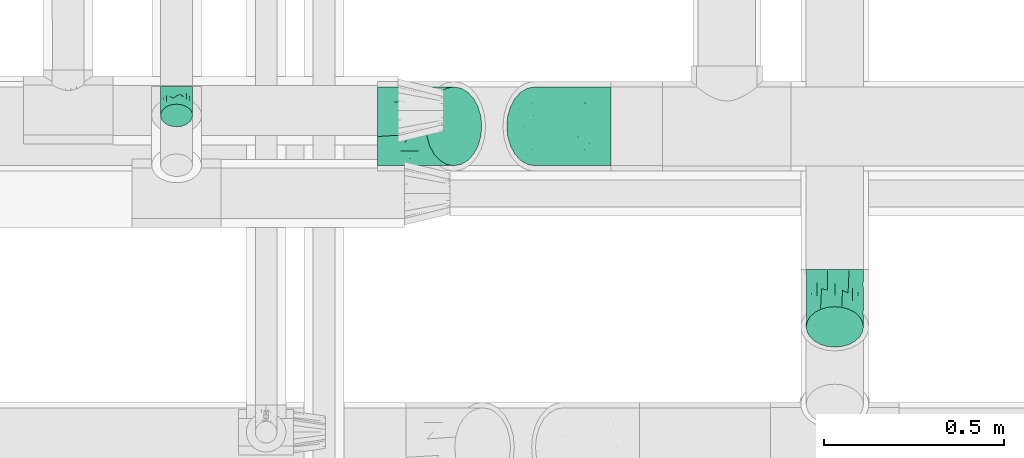
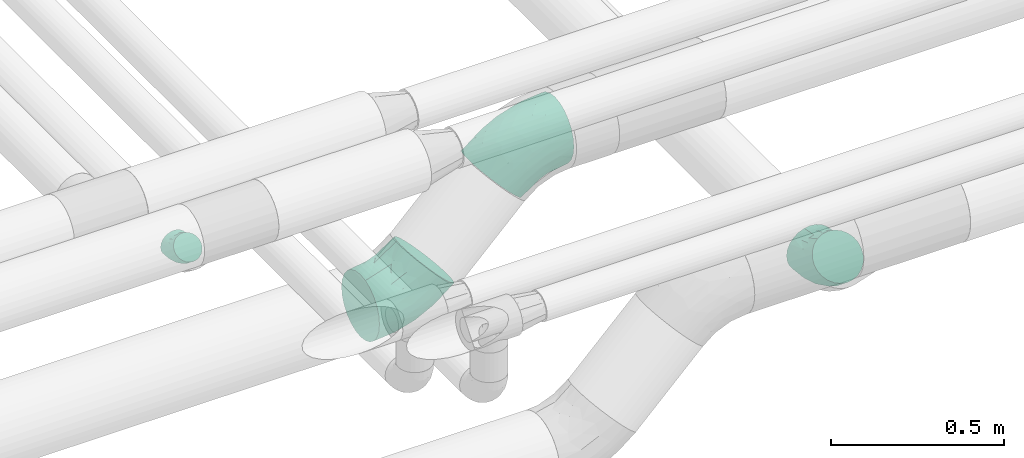
# One storey, part 795 of 827: 4 flow fittings.
"""IFC2X3 building model written with IfcOpenShell, lengths in millimetres."""

from ifc_helpers import new_model, entity, si_unit, converted_unit, derived_unit, direction, frame, origin, place, context, subcontext, project, spatial, faceted_brep, source, transform, mapped, material, type_object, type_shapes, element, save


model = new_model("IFC2X3")

# Units and contexts
model_context = context("Model", 3, precision=0.01, world=origin(), true_north=direction((6.12303176911189e-17, 1.0)))
body_context = subcontext(model_context, "Body", "Model", "MODEL_VIEW")
ifc_project = project(units=[si_unit("LENGTHUNIT", "METRE", prefix="MILLI"), si_unit("AREAUNIT", "SQUARE_METRE"), si_unit("VOLUMEUNIT", "CUBIC_METRE"), converted_unit("PLANEANGLEUNIT", "DEGREE", entity("IfcRatioMeasure", 0.0174532925199433), si_unit("PLANEANGLEUNIT", "RADIAN"), dimensions=[0, 0, 0, 0, 0, 0, 0]), si_unit("MASSUNIT", "GRAM", prefix="KILO"), derived_unit("MASSDENSITYUNIT", [(si_unit("MASSUNIT", "GRAM", prefix="KILO"), 1), (si_unit("LENGTHUNIT", "METRE"), -3)]), derived_unit("MOMENTOFINERTIAUNIT", [(si_unit("LENGTHUNIT", "METRE"), 4)]), si_unit("TIMEUNIT", "SECOND"), si_unit("FREQUENCYUNIT", "HERTZ"), si_unit("THERMODYNAMICTEMPERATUREUNIT", "DEGREE_CELSIUS"), derived_unit("THERMALTRANSMITTANCEUNIT", [(si_unit("MASSUNIT", "GRAM", prefix="KILO"), 1), (si_unit("THERMODYNAMICTEMPERATUREUNIT", "KELVIN"), -1), (si_unit("TIMEUNIT", "SECOND"), -3)]), derived_unit("VOLUMETRICFLOWRATEUNIT", [(si_unit("LENGTHUNIT", "METRE"), 3), (si_unit("TIMEUNIT", "SECOND"), -1)]), derived_unit("MASSFLOWRATEUNIT", [(si_unit("MASSUNIT", "GRAM", prefix="KILO"), 1), (si_unit("TIMEUNIT", "SECOND"), -1)]), derived_unit("ROTATIONALFREQUENCYUNIT", [(si_unit("TIMEUNIT", "SECOND"), -1)]), si_unit("ELECTRICCURRENTUNIT", "AMPERE"), si_unit("ELECTRICVOLTAGEUNIT", "VOLT"), si_unit("POWERUNIT", "WATT"), si_unit("FORCEUNIT", "NEWTON", prefix="KILO"), si_unit("ILLUMINANCEUNIT", "LUX"), si_unit("LUMINOUSFLUXUNIT", "LUMEN"), si_unit("LUMINOUSINTENSITYUNIT", "CANDELA"), derived_unit("USERDEFINED", [(si_unit("MASSUNIT", "GRAM", prefix="KILO"), -1), (si_unit("LENGTHUNIT", "METRE"), -2), (si_unit("TIMEUNIT", "SECOND"), 3), (si_unit("LUMINOUSFLUXUNIT", "LUMEN"), 1)]), derived_unit("LINEARVELOCITYUNIT", [(si_unit("LENGTHUNIT", "METRE"), 1), (si_unit("TIMEUNIT", "SECOND"), -1)]), si_unit("PRESSUREUNIT", "PASCAL"), derived_unit("USERDEFINED", [(si_unit("LENGTHUNIT", "METRE"), -2), (si_unit("MASSUNIT", "GRAM", prefix="KILO"), 1), (si_unit("TIMEUNIT", "SECOND"), -2)]), derived_unit("LINEARFORCEUNIT", [(si_unit("MASSUNIT", "GRAM", prefix="KILO"), 1), (si_unit("LENGTHUNIT", "METRE"), 1), (si_unit("TIMEUNIT", "SECOND"), -2), (si_unit("LENGTHUNIT", "METRE"), -1)]), derived_unit("PLANARFORCEUNIT", [(si_unit("MASSUNIT", "GRAM", prefix="KILO"), 1), (si_unit("LENGTHUNIT", "METRE"), 1), (si_unit("TIMEUNIT", "SECOND"), -2), (si_unit("LENGTHUNIT", "METRE"), -2)])], contexts=[model_context])

# Site, building, storey
site_placement = place(None, origin())
site = spatial("IfcSite", under=ifc_project, at=site_placement, CompositionType="ELEMENT")
building_placement = place(site_placement, origin())
building = spatial("IfcBuilding", under=site, at=building_placement, CompositionType="ELEMENT")
storey_placement = place(building_placement, frame((0.0, 0.0, 28200.0)))
storey = spatial("IfcBuildingStorey", under=building, at=storey_placement, Name="08", CompositionType="ELEMENT", Elevation=28200.0)

# Flow fittings
ifc_material = material()
pipe_fitting_type_1 = type_object("IfcPipeFittingType", Name="ADSK_1", PredefinedType="NOTDEFINED", material=ifc_material)
shared_shape_1 = source(origin(), body_context, "Body", "Brep", [
    faceted_brep([(-47.22, 22.22, -38.49), (-47.22, 11.5, -42.94), (-47.22, 0.0, -44.45), (-47.22, -11.5, -42.94), (-47.22, -22.23, -38.49), (-47.22, -31.43, -31.43), (-47.22, -38.49, -22.23), (-47.22, -42.94, -11.5), (-47.22, -44.45, 0.0), (-47.22, -42.94, 11.5), (-47.22, -38.49, 22.22), (-47.22, -31.43, 31.43), (-47.22, -22.23, 38.49), (-47.22, -11.5, 42.94), (-47.22, 0.0, 44.45), (-47.22, 11.5, 42.94), (-47.22, 22.22, 38.49), (-47.22, 31.43, 31.43), (-47.22, 38.49, 22.22), (-47.22, 42.94, 11.5), (-47.22, 44.45, 0.0), (-47.22, 42.94, -11.5), (-47.22, 38.49, -22.23), (-47.22, 31.43, -31.43), (33.39, 33.39, -44.45), (25.25, 41.52, -42.94), (17.67, 49.11, -38.49), (11.16, 55.61, -31.43), (6.17, 60.61, -22.23), (3.03, 63.75, -11.5), (1.96, 64.82, 0.0), (3.03, 63.75, 11.5), (6.17, 60.61, 22.22), (11.16, 55.61, 31.43), (17.67, 49.11, 38.49), (25.25, 41.52, 42.94), (33.39, 33.39, 44.45), (41.52, 25.25, 42.94), (49.11, 17.67, 38.49), (55.61, 11.16, 31.43), (60.61, 6.17, 22.22), (63.75, 3.03, 11.5), (64.82, 1.96, 0.0), (63.75, 3.03, -11.5), (60.61, 6.17, -22.23), (55.61, 11.16, -31.43), (49.11, 17.67, -38.49), (41.52, 25.25, -42.94), (-19.98, -33.35, 26.29), (-11.97, -37.49, 15.83), (10.37, -25.04, 25.37), (-25.25, -41.56, 0.0), (-6.21, -39.05, 0.0), (-16.68, -40.78, 7.79), (-13.8, -24.01, 34.53), (37.71, -9.45, 26.29), (6.35, -15.34, 36.05), (-23.74, -15.68, 40.73), (15.3, 24.82, 44.16), (-17.26, -3.14, 43.91), (-5.19, 12.53, 44.25), (-28.37, 6.73, 44.16), (26.74, -7.21, 34.53), (27.87, 5.7, 40.73), (-21.13, 19.57, 41.46), (-13.51, 32.62, 36.11), (13.22, -28.64, 17.37), (13.09, -31.61, 8.64), (-23.75, 38.2, 27.85), (-19.13, 46.18, 18.12), (40.63, -17.04, 7.79), (47.24, -11.53, 0.0), (-14.96, 51.28, 9.26), (14.43, 9.99, 43.91), (3.57, -8.62, 40.32), (-4.38, 47.42, 27.62), (34.97, -18.05, 15.83), (3.7, 30.44, 41.41), (-20.6, 49.74, 0.0), (12.9, -31.14, 0.0), (32.0, -23.22, 0.0), (-17.26, -3.14, -43.91), (-16.68, -40.78, -7.79), (13.07, -31.55, -8.93), (1.1, 28.78, -41.46), (-28.37, 6.73, -44.16), (-19.13, 46.18, -18.12), (26.74, -7.21, -34.53), (-13.51, 32.62, -36.11), (34.97, -18.05, -15.83), (-30.43, 36.63, -27.62), (14.43, 9.99, -43.91), (-25.68, 46.84, -9.26), (-24.14, 18.91, -41.41), (-11.97, -37.49, -15.83), (37.71, -9.45, -26.29), (-19.98, -33.35, -26.29), (10.37, -25.04, -25.37), (10.46, -29.71, -17.51), (-13.8, -24.01, -34.53), (6.35, -15.34, -36.05), (3.57, -8.62, -40.32), (27.87, 5.7, -40.73), (-23.74, -15.68, -40.73), (-10.21, 43.8, -27.85), (40.63, -17.04, -7.79), (15.3, 24.82, -44.16), (-5.19, 12.53, -44.25)], [[[0, 1, 2, 3, 4, 5, 6, 7, 8, 9, 10, 11, 12, 13, 14, 15, 16, 17, 18, 19, 20, 21, 22, 23]], [[24, 25, 26, 27, 28, 29, 30, 31, 32, 33, 34, 35, 36, 37, 38, 39, 40, 41, 42, 43, 44, 45, 46, 47]], [[48, 49, 50]], [[51, 52, 53]], [[12, 11, 54]], [[40, 39, 55]], [[54, 56, 57]], [[48, 11, 10]], [[36, 35, 58]], [[13, 12, 57]], [[59, 60, 61]], [[14, 13, 59]], [[62, 55, 39]], [[38, 37, 63]], [[61, 15, 14]], [[16, 64, 65]], [[9, 51, 53]], [[34, 33, 65]], [[66, 49, 67]], [[65, 17, 16]], [[18, 17, 68]], [[18, 68, 69]], [[19, 18, 69]], [[41, 70, 71]], [[72, 20, 19]], [[52, 67, 53]], [[49, 53, 67]], [[16, 15, 64]], [[36, 58, 73]], [[39, 38, 62]], [[74, 73, 59]], [[73, 37, 36]], [[75, 65, 33]], [[76, 40, 55]], [[60, 58, 77]], [[62, 38, 63]], [[17, 65, 68]], [[70, 41, 76]], [[49, 48, 10]], [[61, 64, 15]], [[56, 50, 62]], [[19, 69, 72]], [[10, 9, 49]], [[78, 72, 30]], [[48, 54, 11]], [[31, 72, 69]], [[74, 63, 73]], [[69, 68, 75]], [[55, 62, 50]], [[32, 75, 33]], [[57, 59, 13]], [[35, 34, 77]], [[77, 65, 64]], [[56, 74, 57]], [[60, 59, 73]], [[76, 41, 40]], [[54, 48, 50]], [[32, 31, 69]], [[76, 55, 50]], [[65, 77, 34]], [[60, 77, 64]], [[54, 57, 12]], [[59, 57, 74]], [[73, 63, 37]], [[63, 74, 56]], [[9, 8, 51]], [[67, 52, 79, 80]], [[9, 53, 49]], [[70, 67, 80]], [[67, 76, 66]], [[71, 70, 80]], [[71, 42, 41]], [[67, 70, 76]], [[59, 61, 14]], [[64, 61, 60]], [[77, 58, 35]], [[73, 58, 60]], [[69, 75, 32]], [[65, 75, 68]], [[30, 72, 31]], [[72, 78, 20]], [[50, 56, 54]], [[63, 56, 62]], [[76, 50, 66]], [[49, 66, 50]], [[3, 2, 81]], [[52, 82, 83]], [[26, 25, 84]], [[2, 1, 85]], [[86, 22, 21]], [[46, 45, 87]], [[88, 0, 23]], [[44, 43, 89]], [[22, 90, 23]], [[24, 47, 91]], [[86, 21, 92]], [[1, 0, 93]], [[82, 7, 94]], [[89, 95, 44]], [[96, 97, 98]], [[96, 94, 6]], [[5, 4, 99]], [[100, 101, 102]], [[7, 6, 94]], [[5, 96, 6]], [[103, 4, 3]], [[90, 88, 23]], [[99, 96, 5]], [[28, 27, 104]], [[20, 78, 92]], [[27, 88, 104]], [[30, 29, 92]], [[100, 97, 99]], [[88, 84, 93]], [[28, 86, 29]], [[27, 26, 88]], [[103, 99, 4]], [[84, 88, 26]], [[104, 90, 86]], [[85, 81, 2]], [[104, 86, 28]], [[43, 71, 105]], [[106, 25, 24]], [[102, 47, 46]], [[7, 82, 51]], [[44, 95, 45]], [[102, 87, 100]], [[95, 87, 45]], [[107, 106, 91]], [[97, 95, 89]], [[107, 91, 81]], [[105, 71, 80]], [[102, 91, 47]], [[101, 103, 81]], [[82, 94, 83]], [[101, 81, 91]], [[98, 89, 83]], [[106, 84, 25]], [[29, 86, 92]], [[107, 85, 93]], [[96, 99, 97]], [[87, 95, 97]], [[88, 93, 0]], [[107, 93, 84]], [[81, 103, 3]], [[103, 101, 100]], [[87, 102, 46]], [[91, 102, 101]], [[51, 82, 52]], [[51, 8, 7]], [[98, 83, 94]], [[105, 83, 89]], [[83, 80, 79, 52]], [[43, 42, 71]], [[83, 105, 80]], [[43, 105, 89]], [[93, 85, 1]], [[81, 85, 107]], [[91, 106, 24]], [[84, 106, 107]], [[86, 90, 22]], [[88, 90, 104]], [[20, 92, 21]], [[92, 78, 30]], [[97, 100, 87]], [[103, 100, 99]], [[96, 98, 94]], [[89, 98, 97]]]),
])
type_shapes(pipe_fitting_type_1, [shared_shape_1])
flow_fitting_1_placement = place(storey_placement, frame((36220.03, 7329.73, 2850.0), z_axis=(-1.0, 0.0, 0.0), x_axis=(0.0, -1.0, 0.0)))
element("IfcFlowFitting", 1, at=flow_fitting_1_placement, inside=storey, type_object=pipe_fitting_type_1, material=ifc_material, Name="ADSK_1", ObjectType="ADSK_1", context=body_context, shape_type="MappedRepresentation", body=[
    mapped(shared_shape_1, transform((0.0, 0.0, 0.0), scale=1.0)),
])
pipe_fitting_type_2 = type_object("IfcPipeFittingType", Name="ADSK_2", PredefinedType="NOTDEFINED", material=ifc_material)
shared_shape_2 = source(origin(), body_context, "Body", "Brep", [
    faceted_brep([(-124.26, 54.75, -94.83), (-124.26, 28.34, -105.77), (-124.26, 0.0, -109.5), (-124.26, -28.34, -105.77), (-124.26, -54.75, -94.83), (-124.26, -77.43, -77.43), (-124.26, -94.83, -54.75), (-124.26, -105.77, -28.34), (-124.26, -109.5, 0.0), (-124.26, -105.77, 28.34), (-124.26, -94.83, 54.75), (-124.26, -77.43, 77.43), (-124.26, -54.75, 94.83), (-124.26, -28.34, 105.77), (-124.26, 0.0, 109.5), (-124.26, 28.34, 105.77), (-124.26, 54.75, 94.83), (-124.26, 77.43, 77.43), (-124.26, 94.83, 54.75), (-124.26, 105.77, 28.34), (-124.26, 109.5, 0.0), (-124.26, 105.77, -28.34), (-124.26, 94.83, -54.75), (-124.26, 77.43, -77.43), (87.87, 87.86, -109.5), (67.83, 107.9, -105.77), (49.15, 126.58, -94.83), (33.12, 142.61, -77.43), (20.81, 154.92, -54.75), (13.08, 162.65, -28.34), (10.44, 165.29, 0.0), (13.08, 162.65, 28.34), (20.81, 154.92, 54.75), (33.12, 142.61, 77.43), (49.15, 126.58, 94.83), (67.83, 107.9, 105.77), (87.87, 87.86, 109.5), (107.91, 67.82, 105.77), (126.58, 49.15, 94.83), (142.62, 33.11, 77.43), (154.92, 20.81, 54.75), (162.66, 13.07, 28.34), (165.29, 10.43, 0.0), (162.66, 13.07, -28.34), (154.92, 20.81, -54.75), (142.62, 33.11, -77.43), (126.58, 49.15, -94.83), (107.91, 67.82, -105.77), (71.65, 17.62, 100.41), (2.28, -89.46, 0.0), (-32.68, -94.9, 29.76), (-60.2, -104.46, 0.0), (40.7, 64.69, 108.77), (-50.5, -81.19, 64.81), (-37.02, -58.34, 85.18), (-45.56, -6.91, 108.2), (14.88, -35.92, 89.14), (-63.13, -38.21, 100.41), (-13.48, 32.55, 108.99), (10.95, 77.8, 101.97), (-55.1, 49.0, 102.07), (-33.95, 81.95, 88.86), (-74.53, 16.96, 108.77), (31.61, -76.31, 21.78), (90.21, -44.0, 29.76), (-61.62, 94.79, 68.49), (-47.74, 115.26, 44.52), (27.74, -66.97, 50.42), (-65.18, -94.31, 47.39), (-34.75, 129.14, 22.76), (-87.1, 113.16, 0.0), (61.64, -64.87, 0.0), (116.43, -31.3, 0.0), (67.43, -15.08, 85.18), (80.19, -41.7, 48.45), (93.12, -21.7, 64.81), (37.1, 27.33, 108.2), (15.29, -56.47, 71.64), (-8.95, 119.52, 68.0), (-18.43, 141.6, 0.0), (-51.36, 124.0, 0.0), (8.08, -19.5, 99.45), (-74.53, 16.96, -108.77), (-45.56, -6.91, -108.2), (90.21, -44.0, -29.76), (-33.95, 81.95, -88.86), (4.32, 73.61, -102.07), (-66.74, 115.88, -22.76), (71.65, 17.62, -100.41), (37.1, 27.33, -108.2), (-47.74, 115.26, -44.52), (-50.5, -81.19, -64.81), (-37.02, -58.34, -85.18), (-78.18, 90.84, -68.0), (-62.76, 47.28, -101.97), (-27.22, -86.19, -48.45), (-63.13, -38.21, -100.41), (-32.68, -94.9, -29.76), (-13.48, 32.55, -108.99), (8.08, -19.5, -99.45), (14.88, -35.92, -89.14), (27.74, -66.97, -50.42), (31.61, -76.31, -21.78), (29.12, -50.74, -71.64), (93.12, -21.7, -64.81), (112.78, -20.6, -47.39), (-23.45, 110.59, -68.49), (67.43, -15.08, -85.18), (40.7, 64.69, -108.77)], [[[0, 1, 2, 3, 4, 5, 6, 7, 8, 9, 10, 11, 12, 13, 14, 15, 16, 17, 18, 19, 20, 21, 22, 23]], [[24, 25, 26, 27, 28, 29, 30, 31, 32, 33, 34, 35, 36, 37, 38, 39, 40, 41, 42, 43, 44, 45, 46, 47]], [[38, 37, 48]], [[49, 50, 51]], [[36, 35, 52]], [[11, 53, 54]], [[51, 9, 8]], [[14, 13, 55]], [[56, 57, 54]], [[58, 59, 60]], [[34, 33, 61]], [[13, 12, 57]], [[55, 58, 62]], [[49, 63, 50]], [[54, 57, 12]], [[16, 15, 60]], [[40, 64, 41]], [[61, 16, 60]], [[9, 51, 50]], [[18, 65, 66]], [[15, 14, 62]], [[67, 53, 68]], [[32, 31, 66]], [[19, 69, 70]], [[12, 11, 54]], [[70, 20, 19]], [[19, 18, 66]], [[53, 11, 10]], [[61, 17, 16]], [[18, 17, 65]], [[64, 63, 71]], [[72, 41, 64]], [[38, 73, 39]], [[74, 75, 67]], [[58, 52, 59]], [[52, 76, 36]], [[63, 67, 50]], [[76, 37, 36]], [[77, 53, 67]], [[40, 75, 74]], [[78, 61, 33]], [[38, 48, 73]], [[68, 53, 10]], [[72, 42, 41]], [[77, 75, 73]], [[17, 61, 65]], [[69, 30, 79]], [[79, 80, 69]], [[68, 9, 50]], [[75, 39, 73]], [[57, 56, 81]], [[66, 69, 19]], [[81, 76, 55]], [[66, 65, 78]], [[66, 31, 69]], [[78, 33, 32]], [[81, 48, 76]], [[57, 55, 13]], [[58, 55, 76]], [[34, 59, 35]], [[59, 61, 60]], [[77, 54, 53]], [[62, 60, 15]], [[72, 64, 71]], [[61, 59, 34]], [[40, 39, 75]], [[55, 57, 81]], [[76, 48, 37]], [[48, 81, 56]], [[75, 77, 67]], [[56, 77, 73]], [[66, 78, 32]], [[61, 78, 65]], [[55, 62, 14]], [[60, 62, 58]], [[59, 52, 35]], [[76, 52, 58]], [[71, 63, 49]], [[67, 63, 64]], [[69, 31, 30]], [[69, 80, 70]], [[77, 56, 54]], [[48, 56, 73]], [[9, 68, 10]], [[67, 68, 50]], [[67, 64, 74]], [[40, 74, 64]], [[1, 82, 2]], [[82, 83, 2]], [[83, 3, 2]], [[43, 72, 84]], [[23, 85, 0]], [[26, 25, 86]], [[70, 87, 20]], [[88, 89, 47]], [[90, 22, 21]], [[91, 5, 92]], [[93, 23, 22]], [[85, 86, 94]], [[6, 5, 91]], [[94, 1, 0]], [[6, 91, 95]], [[85, 94, 0]], [[51, 8, 7]], [[83, 96, 3]], [[49, 51, 97]], [[98, 94, 86]], [[4, 92, 5]], [[99, 96, 83]], [[88, 100, 99]], [[101, 84, 102]], [[96, 4, 3]], [[92, 4, 96]], [[95, 91, 101]], [[90, 21, 87]], [[70, 80, 87]], [[103, 91, 92]], [[101, 104, 105]], [[104, 45, 44]], [[29, 87, 79]], [[29, 79, 30]], [[106, 93, 90]], [[28, 90, 29]], [[27, 26, 85]], [[105, 43, 84]], [[86, 85, 26]], [[6, 97, 7]], [[46, 45, 107]], [[106, 90, 28]], [[28, 27, 106]], [[108, 25, 24]], [[88, 47, 46]], [[103, 107, 104]], [[51, 7, 97]], [[71, 49, 102]], [[107, 100, 88]], [[98, 108, 89]], [[97, 102, 49]], [[27, 85, 106]], [[42, 72, 43]], [[108, 86, 25]], [[99, 83, 89]], [[72, 71, 84]], [[98, 82, 94]], [[45, 104, 107]], [[93, 85, 23]], [[24, 47, 89]], [[105, 104, 44]], [[29, 90, 87]], [[103, 104, 101]], [[98, 89, 83]], [[96, 99, 100]], [[107, 88, 46]], [[89, 88, 99]], [[91, 103, 101]], [[100, 103, 92]], [[90, 93, 22]], [[85, 93, 106]], [[94, 82, 1]], [[83, 82, 98]], [[89, 108, 24]], [[86, 108, 98]], [[101, 102, 97]], [[71, 102, 84]], [[87, 21, 20]], [[87, 80, 79]], [[103, 100, 107]], [[96, 100, 92]], [[43, 105, 44]], [[101, 105, 84]], [[101, 97, 95]], [[6, 95, 97]]]),
])
type_shapes(pipe_fitting_type_2, [shared_shape_2])
flow_fitting_2_placement = place(storey_placement, frame((36902.44, 7266.2, 2499.96), z_axis=(0.0, 1.0, 0.0), x_axis=(-0.707128324867813, 0.0, -0.707085236848883)))
element("IfcFlowFitting", 2, at=flow_fitting_2_placement, inside=storey, type_object=pipe_fitting_type_2, material=ifc_material, Name="ADSK_2", ObjectType="ADSK_2", context=body_context, shape_type="MappedRepresentation", body=[
    mapped(shared_shape_2, transform((0.0, 0.0, 0.0), scale=1.0)),
])
pipe_fitting_type_3 = type_object("IfcPipeFittingType", Name="ADSK_2", PredefinedType="NOTDEFINED", material=ifc_material)
shared_shape_3 = source(origin(), body_context, "Body", "Brep", [
    faceted_brep([(-124.27, 54.75, -94.83), (-124.27, 28.34, -105.77), (-124.27, 0.0, -109.5), (-124.27, -28.34, -105.77), (-124.27, -54.75, -94.83), (-124.27, -77.43, -77.43), (-124.27, -94.83, -54.75), (-124.27, -105.77, -28.34), (-124.27, -109.5, 0.0), (-124.27, -105.77, 28.34), (-124.27, -94.83, 54.75), (-124.27, -77.43, 77.43), (-124.27, -54.75, 94.83), (-124.27, -28.34, 105.77), (-124.27, 0.0, 109.5), (-124.27, 28.34, 105.77), (-124.27, 54.75, 94.83), (-124.27, 77.43, 77.43), (-124.27, 94.83, 54.75), (-124.27, 105.77, 28.34), (-124.27, 109.5, 0.0), (-124.27, 105.77, -28.34), (-124.27, 94.83, -54.75), (-124.27, 77.43, -77.43), (87.87, 87.87, -109.5), (67.83, 107.91, -105.77), (49.15, 126.59, -94.83), (33.12, 142.62, -77.43), (20.81, 154.93, -54.75), (13.08, 162.66, -28.34), (10.44, 165.3, 0.0), (13.08, 162.66, 28.34), (20.81, 154.93, 54.75), (33.12, 142.62, 77.43), (49.15, 126.59, 94.83), (67.83, 107.91, 105.77), (87.87, 87.87, 109.5), (107.91, 67.83, 105.77), (126.58, 49.16, 94.83), (142.62, 33.12, 77.43), (154.93, 20.82, 54.75), (162.66, 13.08, 28.34), (165.3, 10.45, 0.0), (162.66, 13.08, -28.34), (154.93, 20.82, -54.75), (142.62, 33.12, -77.43), (126.58, 49.16, -94.83), (107.91, 67.83, -105.77), (71.66, 17.62, 100.41), (2.28, -89.46, 0.0), (-32.68, -94.9, 29.76), (-60.21, -104.46, 0.0), (40.7, 64.7, 108.77), (-50.51, -81.19, 64.81), (-37.02, -58.34, 85.18), (-45.57, -6.91, 108.2), (14.88, -35.92, 89.14), (-63.13, -38.21, 100.41), (-13.48, 32.55, 108.99), (10.95, 77.81, 101.97), (-55.11, 49.0, 102.07), (-33.95, 81.96, 88.86), (-74.53, 16.96, 108.77), (31.61, -76.3, 21.78), (90.21, -43.99, 29.76), (-61.62, 94.79, 68.49), (-47.74, 115.26, 44.52), (27.74, -66.97, 50.42), (-65.19, -94.31, 47.39), (-34.75, 129.14, 22.76), (-87.1, 113.16, 0.0), (61.65, -64.86, 0.0), (116.44, -31.29, 0.0), (67.43, -15.08, 85.18), (80.19, -41.7, 48.45), (93.12, -21.69, 64.81), (37.11, 27.33, 108.2), (15.28, -56.47, 71.64), (-8.95, 119.52, 68.0), (-18.43, 141.61, 0.0), (-51.36, 124.0, 0.0), (8.08, -19.5, 99.45), (-74.53, 16.96, -108.77), (-45.57, -6.91, -108.2), (90.21, -43.99, -29.76), (-33.95, 81.96, -88.86), (4.32, 73.62, -102.07), (-66.75, 115.89, -22.76), (71.66, 17.62, -100.41), (37.11, 27.33, -108.2), (-47.74, 115.26, -44.52), (-50.51, -81.19, -64.81), (-37.02, -58.34, -85.18), (-78.19, 90.84, -68.0), (-62.76, 47.28, -101.97), (-27.22, -86.19, -48.45), (-63.13, -38.21, -100.41), (-32.68, -94.9, -29.76), (-13.48, 32.55, -108.99), (8.08, -19.5, -99.45), (14.88, -35.92, -89.14), (27.74, -66.97, -50.42), (31.61, -76.3, -21.78), (29.13, -50.73, -71.64), (93.12, -21.69, -64.81), (112.78, -20.59, -47.39), (-23.45, 110.6, -68.49), (67.43, -15.08, -85.18), (40.7, 64.7, -108.77)], [[[0, 1, 2, 3, 4, 5, 6, 7, 8, 9, 10, 11, 12, 13, 14, 15, 16, 17, 18, 19, 20, 21, 22, 23]], [[24, 25, 26, 27, 28, 29, 30, 31, 32, 33, 34, 35, 36, 37, 38, 39, 40, 41, 42, 43, 44, 45, 46, 47]], [[38, 37, 48]], [[49, 50, 51]], [[36, 35, 52]], [[11, 53, 54]], [[51, 9, 8]], [[14, 13, 55]], [[56, 57, 54]], [[58, 59, 60]], [[34, 33, 61]], [[13, 12, 57]], [[55, 58, 62]], [[49, 63, 50]], [[54, 57, 12]], [[16, 15, 60]], [[40, 64, 41]], [[61, 16, 60]], [[9, 51, 50]], [[18, 65, 66]], [[15, 14, 62]], [[67, 53, 68]], [[32, 31, 66]], [[19, 69, 70]], [[12, 11, 54]], [[70, 20, 19]], [[19, 18, 66]], [[53, 11, 10]], [[61, 17, 16]], [[18, 17, 65]], [[64, 63, 71]], [[72, 41, 64]], [[38, 73, 39]], [[74, 75, 67]], [[58, 52, 59]], [[52, 76, 36]], [[63, 67, 50]], [[76, 37, 36]], [[77, 53, 67]], [[40, 75, 74]], [[78, 61, 33]], [[38, 48, 73]], [[68, 53, 10]], [[72, 42, 41]], [[77, 75, 73]], [[17, 61, 65]], [[69, 30, 79]], [[79, 80, 69]], [[68, 9, 50]], [[75, 39, 73]], [[57, 56, 81]], [[66, 69, 19]], [[81, 76, 55]], [[66, 65, 78]], [[66, 31, 69]], [[78, 33, 32]], [[81, 48, 76]], [[57, 55, 13]], [[58, 55, 76]], [[34, 59, 35]], [[59, 61, 60]], [[77, 54, 53]], [[62, 60, 15]], [[72, 64, 71]], [[61, 59, 34]], [[40, 39, 75]], [[55, 57, 81]], [[76, 48, 37]], [[48, 81, 56]], [[75, 77, 67]], [[56, 77, 73]], [[66, 78, 32]], [[61, 78, 65]], [[55, 62, 14]], [[60, 62, 58]], [[59, 52, 35]], [[76, 52, 58]], [[71, 63, 49]], [[67, 63, 64]], [[69, 31, 30]], [[69, 80, 70]], [[77, 56, 54]], [[48, 56, 73]], [[9, 68, 10]], [[67, 68, 50]], [[67, 64, 74]], [[40, 74, 64]], [[1, 82, 2]], [[82, 83, 2]], [[83, 3, 2]], [[43, 72, 84]], [[23, 85, 0]], [[26, 25, 86]], [[70, 87, 20]], [[88, 89, 47]], [[90, 22, 21]], [[91, 5, 92]], [[93, 23, 22]], [[85, 86, 94]], [[6, 5, 91]], [[94, 1, 0]], [[6, 91, 95]], [[85, 94, 0]], [[51, 8, 7]], [[83, 96, 3]], [[49, 51, 97]], [[98, 94, 86]], [[4, 92, 5]], [[99, 96, 83]], [[88, 100, 99]], [[101, 84, 102]], [[96, 4, 3]], [[92, 4, 96]], [[95, 91, 101]], [[90, 21, 87]], [[70, 80, 87]], [[103, 91, 92]], [[101, 104, 105]], [[104, 45, 44]], [[29, 87, 79]], [[29, 79, 30]], [[106, 93, 90]], [[28, 90, 29]], [[27, 26, 85]], [[105, 43, 84]], [[86, 85, 26]], [[6, 97, 7]], [[46, 45, 107]], [[106, 90, 28]], [[28, 27, 106]], [[108, 25, 24]], [[88, 47, 46]], [[103, 107, 104]], [[51, 7, 97]], [[71, 49, 102]], [[107, 100, 88]], [[98, 108, 89]], [[97, 102, 49]], [[27, 85, 106]], [[42, 72, 43]], [[108, 86, 25]], [[99, 83, 89]], [[72, 71, 84]], [[98, 82, 94]], [[45, 104, 107]], [[93, 85, 23]], [[24, 47, 89]], [[105, 104, 44]], [[29, 90, 87]], [[103, 104, 101]], [[98, 89, 83]], [[96, 99, 100]], [[107, 88, 46]], [[89, 88, 99]], [[91, 103, 101]], [[100, 103, 92]], [[90, 93, 22]], [[85, 93, 106]], [[94, 82, 1]], [[83, 82, 98]], [[89, 108, 24]], [[86, 108, 98]], [[101, 102, 97]], [[71, 102, 84]], [[87, 21, 20]], [[87, 80, 79]], [[103, 100, 107]], [[96, 100, 92]], [[43, 105, 44]], [[101, 105, 84]], [[101, 97, 95]], [[6, 95, 97]]]),
])
type_shapes(pipe_fitting_type_3, [shared_shape_3])
flow_fitting_3_placement = place(storey_placement, frame((37302.39, 7266.2, 2899.88), z_axis=(0.0, 1.0, 0.0), x_axis=(0.70712832486764, 0.0, 0.707085236849056)))
element("IfcFlowFitting", 3, at=flow_fitting_3_placement, inside=storey, type_object=pipe_fitting_type_3, material=ifc_material, Name="ADSK_2", ObjectType="ADSK_2", context=body_context, shape_type="MappedRepresentation", body=[
    mapped(shared_shape_3, transform((0.0, 0.0, 0.0), scale=1.0)),
])
pipe_fitting_type_4 = type_object("IfcPipeFittingType", Name="ADSK_2", PredefinedType="NOTDEFINED", material=ifc_material)
shared_shape_4 = source(origin(), body_context, "Body", "Brep", [
    faceted_brep([(-93.2, 39.75, -68.85), (-93.2, 20.58, -76.79), (-93.2, 0.0, -79.5), (-93.2, -20.58, -76.79), (-93.2, -39.75, -68.85), (-93.2, -56.21, -56.21), (-93.2, -68.85, -39.75), (-93.2, -76.79, -20.58), (-93.2, -79.5, 0.0), (-93.2, -76.79, 20.58), (-93.2, -68.85, 39.75), (-93.2, -56.21, 56.21), (-93.2, -39.75, 68.85), (-93.2, -20.58, 76.79), (-93.2, 0.0, 79.5), (-93.2, 20.58, 76.79), (-93.2, 39.75, 68.85), (-93.2, 56.21, 56.21), (-93.2, 68.85, 39.75), (-93.2, 76.79, 20.58), (-93.2, 79.5, 0.0), (-93.2, 76.79, -20.58), (-93.2, 68.85, -39.75), (-93.2, 56.21, -56.21), (65.9, 65.9, -79.5), (51.35, 80.45, -76.79), (37.79, 94.01, -68.85), (26.15, 105.65, -56.21), (17.22, 114.58, -39.75), (11.6, 120.2, -20.58), (9.69, 122.12, 0.0), (11.6, 120.2, 20.58), (17.22, 114.58, 39.75), (26.15, 105.65, 56.21), (37.79, 94.01, 68.85), (51.35, 80.45, 76.79), (65.9, 65.9, 79.5), (80.45, 51.35, 76.79), (94.01, 37.79, 68.85), (105.65, 26.15, 56.21), (114.58, 17.22, 39.75), (120.2, 11.6, 20.58), (122.12, 9.69, 0.0), (120.2, 11.6, -20.58), (114.58, 17.22, -39.75), (105.65, 26.15, -56.21), (94.01, 37.79, -68.85), (80.45, 51.35, -76.79), (-47.32, -68.64, 33.28), (-47.95, -73.85, 18.74), (-7.4, -63.3, 23.97), (-33.79, -73.65, 0.0), (53.15, 14.13, 72.92), (-28.01, -42.07, 61.88), (10.52, -25.4, 64.82), (-47.58, -27.59, 72.92), (-40.86, -59.22, 47.17), (-34.22, -4.72, 78.56), (-10.05, 24.26, 79.12), (-55.85, 12.46, 78.97), (-59.18, 65.95, 49.32), (-40.28, 79.83, 36.77), (-24.89, 60.1, 64.48), (8.64, 57.54, 74.02), (-41.16, 35.86, 74.09), (50.57, -42.17, 13.19), (23.33, -56.32, 0.0), (75.97, -28.18, 0.0), (-18.33, 80.23, 49.75), (17.8, -42.96, 45.72), (64.35, -29.37, 28.52), (-36.46, 88.03, 20.73), (-55.54, 84.46, 0.0), (70.76, -12.98, 47.17), (-20.45, 98.99, 0.0), (30.68, 48.3, 78.97), (49.55, -9.94, 61.88), (27.53, 20.86, 78.56), (88.47, -17.66, 14.68), (5.6, -13.52, 72.25), (-46.8, 34.58, -74.02), (-24.89, 60.1, -64.48), (3.74, 54.46, -74.09), (-27.96, 84.93, -36.77), (10.52, -25.4, -64.82), (5.6, -13.52, -72.25), (53.15, 14.13, -72.92), (-36.46, 88.03, -20.73), (-47.58, -27.59, -72.92), (-28.01, -42.07, -61.88), (-43.77, 69.69, -49.75), (-55.85, 12.46, -78.97), (-34.22, -4.72, -78.56), (-24.74, -66.27, -28.52), (-40.86, -59.22, -47.17), (81.99, -15.08, -33.28), (70.76, -12.98, -47.17), (-50.07, -75.05, -14.68), (49.55, -9.94, -61.88), (17.8, -42.96, -45.72), (49.99, -39.53, -23.97), (-5.94, -65.58, -13.19), (86.13, -18.32, -18.74), (-4.79, 88.48, -49.32), (30.68, 48.3, -78.97), (27.53, 20.86, -78.56), (-10.05, 24.26, -79.12)], [[[0, 1, 2, 3, 4, 5, 6, 7, 8, 9, 10, 11, 12, 13, 14, 15, 16, 17, 18, 19, 20, 21, 22, 23]], [[24, 25, 26, 27, 28, 29, 30, 31, 32, 33, 34, 35, 36, 37, 38, 39, 40, 41, 42, 43, 44, 45, 46, 47]], [[48, 49, 50]], [[49, 8, 51]], [[38, 37, 52]], [[12, 11, 53]], [[53, 54, 55]], [[56, 11, 10]], [[14, 13, 57]], [[13, 12, 55]], [[57, 58, 59]], [[60, 61, 18]], [[62, 63, 34]], [[18, 61, 19]], [[16, 15, 64]], [[17, 16, 62]], [[65, 66, 67]], [[60, 62, 68]], [[15, 14, 59]], [[34, 33, 62]], [[69, 50, 70]], [[19, 71, 72]], [[40, 39, 73]], [[72, 20, 19]], [[74, 71, 31]], [[50, 66, 65]], [[62, 16, 64]], [[56, 48, 69]], [[66, 50, 51]], [[36, 35, 75]], [[39, 38, 76]], [[76, 73, 39]], [[32, 31, 61]], [[75, 77, 36]], [[70, 41, 40]], [[77, 37, 36]], [[48, 56, 10]], [[70, 40, 73]], [[59, 64, 15]], [[76, 38, 52]], [[58, 75, 63]], [[42, 41, 78]], [[53, 56, 69]], [[17, 60, 18]], [[54, 79, 55]], [[72, 71, 74]], [[48, 9, 49]], [[30, 74, 31]], [[54, 69, 76]], [[31, 71, 61]], [[58, 57, 77]], [[32, 68, 33]], [[55, 57, 13]], [[68, 62, 33]], [[79, 52, 77]], [[35, 34, 63]], [[63, 62, 64]], [[73, 76, 69]], [[79, 77, 57]], [[78, 70, 65]], [[70, 73, 69]], [[56, 53, 11]], [[58, 63, 64]], [[53, 55, 12]], [[57, 55, 79]], [[77, 52, 37]], [[52, 79, 54]], [[57, 59, 14]], [[64, 59, 58]], [[63, 75, 35]], [[77, 75, 58]], [[9, 48, 10]], [[69, 48, 50]], [[8, 49, 9]], [[51, 50, 49]], [[62, 60, 17]], [[61, 60, 68]], [[32, 61, 68]], [[61, 71, 19]], [[78, 65, 67]], [[50, 65, 70]], [[42, 78, 67]], [[70, 78, 41]], [[69, 54, 53]], [[52, 54, 76]], [[1, 0, 80]], [[81, 82, 80]], [[28, 83, 29]], [[23, 81, 0]], [[20, 72, 21]], [[84, 85, 86]], [[21, 87, 83]], [[88, 89, 4]], [[81, 23, 90]], [[91, 92, 2]], [[26, 25, 82]], [[91, 2, 1]], [[93, 6, 94]], [[95, 96, 44]], [[8, 7, 97]], [[81, 80, 0]], [[93, 7, 6]], [[98, 96, 99]], [[88, 4, 3]], [[100, 66, 101]], [[6, 5, 94]], [[89, 5, 4]], [[2, 92, 3]], [[94, 89, 99]], [[93, 94, 99]], [[96, 98, 45]], [[87, 72, 74]], [[89, 94, 5]], [[74, 30, 29]], [[99, 100, 93]], [[72, 87, 21]], [[95, 43, 102]], [[103, 83, 28]], [[90, 103, 81]], [[26, 82, 81]], [[46, 45, 98]], [[104, 25, 24]], [[96, 95, 99]], [[22, 90, 23]], [[26, 81, 27]], [[84, 99, 89]], [[104, 105, 106]], [[84, 86, 98]], [[27, 103, 28]], [[24, 47, 105]], [[67, 66, 100]], [[44, 96, 45]], [[47, 46, 86]], [[100, 95, 102]], [[85, 92, 105]], [[67, 102, 42]], [[85, 88, 92]], [[106, 105, 92]], [[97, 93, 101]], [[22, 21, 83]], [[101, 66, 51]], [[104, 82, 25]], [[87, 74, 29]], [[106, 91, 80]], [[86, 105, 47]], [[106, 80, 82]], [[92, 88, 3]], [[88, 85, 84]], [[98, 86, 46]], [[105, 86, 85]], [[80, 91, 1]], [[92, 91, 106]], [[105, 104, 24]], [[82, 104, 106]], [[43, 95, 44]], [[99, 95, 100]], [[42, 102, 43]], [[67, 100, 102]], [[81, 103, 27]], [[83, 103, 90]], [[22, 83, 90]], [[83, 87, 29]], [[97, 101, 51]], [[100, 101, 93]], [[8, 97, 51]], [[93, 97, 7]], [[99, 84, 98]], [[88, 84, 89]]]),
])
type_shapes(pipe_fitting_type_4, [shared_shape_4])
flow_fitting_4_placement = place(storey_placement, frame((38048.3, 6775.0, 2500.0), z_axis=(1.0, 0.0, 0.0), x_axis=(0.0, 0.707106781186545, -0.70710678118655)))
element("IfcFlowFitting", 4, at=flow_fitting_4_placement, inside=storey, type_object=pipe_fitting_type_4, material=ifc_material, Name="ADSK_2", ObjectType="ADSK_2", context=body_context, shape_type="MappedRepresentation", body=[
    mapped(shared_shape_4, transform((0.0, 0.0, 0.0), scale=1.0)),
])

save(model, "model.ifc")
